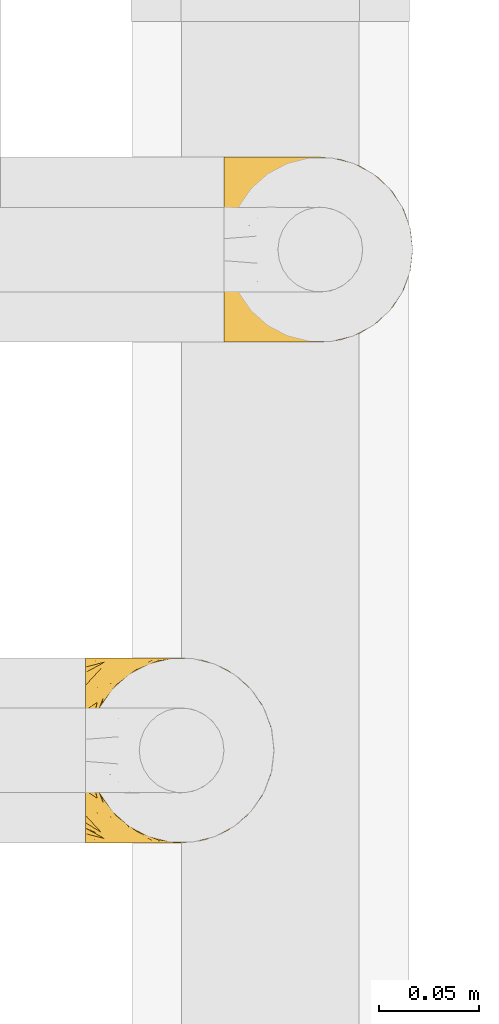
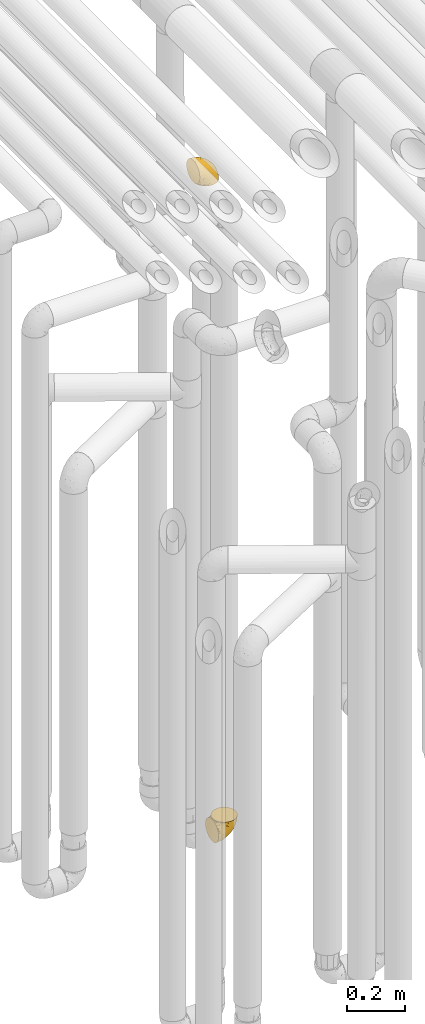
# One storey, part 224 of 827: 2 coverings.
"""IFC2X3 building model written with IfcOpenShell, lengths in millimetres."""

from ifc_helpers import new_model, entity, si_unit, converted_unit, derived_unit, direction, frame, origin, place, context, subcontext, project, spatial, faceted_brep, element, save


model = new_model("IFC2X3")

# Units and contexts
model_context = context("Model", 3, precision=0.01, world=origin(), true_north=direction((6.12303176911189e-17, 1.0)))
body_context = subcontext(model_context, "Body", "Model", "MODEL_VIEW")
ifc_project = project(units=[si_unit("LENGTHUNIT", "METRE", prefix="MILLI"), si_unit("AREAUNIT", "SQUARE_METRE"), si_unit("VOLUMEUNIT", "CUBIC_METRE"), converted_unit("PLANEANGLEUNIT", "DEGREE", entity("IfcRatioMeasure", 0.0174532925199433), si_unit("PLANEANGLEUNIT", "RADIAN"), dimensions=[0, 0, 0, 0, 0, 0, 0]), si_unit("MASSUNIT", "GRAM", prefix="KILO"), derived_unit("MASSDENSITYUNIT", [(si_unit("MASSUNIT", "GRAM", prefix="KILO"), 1), (si_unit("LENGTHUNIT", "METRE"), -3)]), derived_unit("MOMENTOFINERTIAUNIT", [(si_unit("LENGTHUNIT", "METRE"), 4)]), si_unit("TIMEUNIT", "SECOND"), si_unit("FREQUENCYUNIT", "HERTZ"), si_unit("THERMODYNAMICTEMPERATUREUNIT", "DEGREE_CELSIUS"), derived_unit("THERMALTRANSMITTANCEUNIT", [(si_unit("MASSUNIT", "GRAM", prefix="KILO"), 1), (si_unit("THERMODYNAMICTEMPERATUREUNIT", "KELVIN"), -1), (si_unit("TIMEUNIT", "SECOND"), -3)]), derived_unit("VOLUMETRICFLOWRATEUNIT", [(si_unit("LENGTHUNIT", "METRE"), 3), (si_unit("TIMEUNIT", "SECOND"), -1)]), derived_unit("MASSFLOWRATEUNIT", [(si_unit("MASSUNIT", "GRAM", prefix="KILO"), 1), (si_unit("TIMEUNIT", "SECOND"), -1)]), derived_unit("ROTATIONALFREQUENCYUNIT", [(si_unit("TIMEUNIT", "SECOND"), -1)]), si_unit("ELECTRICCURRENTUNIT", "AMPERE"), si_unit("ELECTRICVOLTAGEUNIT", "VOLT"), si_unit("POWERUNIT", "WATT"), si_unit("FORCEUNIT", "NEWTON", prefix="KILO"), si_unit("ILLUMINANCEUNIT", "LUX"), si_unit("LUMINOUSFLUXUNIT", "LUMEN"), si_unit("LUMINOUSINTENSITYUNIT", "CANDELA"), derived_unit("USERDEFINED", [(si_unit("MASSUNIT", "GRAM", prefix="KILO"), -1), (si_unit("LENGTHUNIT", "METRE"), -2), (si_unit("TIMEUNIT", "SECOND"), 3), (si_unit("LUMINOUSFLUXUNIT", "LUMEN"), 1)]), derived_unit("LINEARVELOCITYUNIT", [(si_unit("LENGTHUNIT", "METRE"), 1), (si_unit("TIMEUNIT", "SECOND"), -1)]), si_unit("PRESSUREUNIT", "PASCAL"), derived_unit("USERDEFINED", [(si_unit("LENGTHUNIT", "METRE"), -2), (si_unit("MASSUNIT", "GRAM", prefix="KILO"), 1), (si_unit("TIMEUNIT", "SECOND"), -2)]), derived_unit("LINEARFORCEUNIT", [(si_unit("MASSUNIT", "GRAM", prefix="KILO"), 1), (si_unit("LENGTHUNIT", "METRE"), 1), (si_unit("TIMEUNIT", "SECOND"), -2), (si_unit("LENGTHUNIT", "METRE"), -1)]), derived_unit("PLANARFORCEUNIT", [(si_unit("MASSUNIT", "GRAM", prefix="KILO"), 1), (si_unit("LENGTHUNIT", "METRE"), 1), (si_unit("TIMEUNIT", "SECOND"), -2), (si_unit("LENGTHUNIT", "METRE"), -2)])], contexts=[model_context])

# Site, building, storey
site_placement = place(None, origin())
site = spatial("IfcSite", under=ifc_project, at=site_placement, CompositionType="ELEMENT")
building_placement = place(site_placement, origin())
building = spatial("IfcBuilding", under=site, at=building_placement, CompositionType="ELEMENT")
storey_placement = place(building_placement, frame((0.0, 0.0, 28200.0)))
storey = spatial("IfcBuildingStorey", under=building, at=storey_placement, Name="08", CompositionType="ELEMENT", Elevation=28200.0)

# Coverings
covering_1_placement = place(storey_placement, frame((35824.19, 12708.37, 352.2)))
element("IfcCovering", 1, at=covering_1_placement, inside=storey, Name=":ADSK_", ObjectType=":ADSK_", PredefinedType="INSULATION", context=body_context, shape_type="Brep", body=[
    faceted_brep([(1.6, 83.91, 18.98), (1.6, 76.59, 11.67), (1.6, 67.83, 6.17), (1.6, 58.07, 2.75), (1.6, 47.8, 1.6), (1.6, 37.51, 2.75), (1.6, 27.74, 6.17), (1.6, 18.98, 11.68), (1.6, 11.67, 19.0), (1.6, 6.17, 27.76), (1.6, 2.75, 37.52), (1.6, 1.6, 47.8), (1.6, 2.06, 51.94), (1.6, 2.41, 55.01), (1.6, 2.75, 58.08), (1.6, 4.46, 62.96), (1.6, 6.17, 67.85), (1.6, 8.93, 72.23), (1.6, 11.68, 76.61), (1.6, 15.34, 80.26), (1.6, 19.0, 83.92), (1.6, 27.76, 89.42), (1.6, 32.64, 91.13), (1.6, 37.52, 92.84), (1.6, 47.8, 94.0), (1.6, 58.08, 92.84), (1.6, 62.96, 91.13), (1.6, 67.85, 89.42), (1.6, 76.61, 83.91), (1.6, 80.26, 80.25), (1.6, 83.92, 76.59), (1.6, 86.67, 72.21), (1.6, 89.42, 67.83), (1.6, 91.13, 62.95), (1.6, 92.84, 58.07), (1.6, 93.18, 55.0), (1.6, 93.53, 51.94), (1.6, 94.0, 47.8), (1.6, 92.84, 37.51), (1.6, 89.42, 27.74), (3.4, 47.8, 95.8), (4.97, 35.84, 95.8), (9.58, 24.7, 95.8), (13.26, 19.91, 95.8), (16.93, 15.13, 95.8), (21.71, 11.46, 95.8), (26.5, 7.78, 95.8), (32.07, 5.48, 95.8), (37.64, 3.17, 95.8), (41.25, 2.69, 95.8), (43.34, 2.42, 95.8), (45.42, 2.14, 95.8), (49.6, 1.6, 95.8), (61.55, 3.17, 95.8), (72.7, 7.78, 95.8), (82.26, 15.13, 95.8), (89.61, 24.7, 95.8), (94.22, 35.84, 95.8), (95.8, 47.8, 95.8), (94.22, 59.75, 95.8), (89.61, 70.9, 95.8), (82.26, 80.46, 95.8), (72.7, 87.81, 95.8), (61.55, 92.42, 95.8), (49.6, 94.0, 95.8), (45.42, 93.45, 95.8), (41.25, 92.9, 95.8), (37.64, 92.42, 95.8), (32.07, 90.11, 95.8), (26.5, 87.81, 95.8), (21.71, 84.13, 95.8), (16.93, 80.46, 95.8), (13.26, 75.68, 95.8), (9.58, 70.9, 95.8), (4.97, 59.75, 95.8), (81.55, 71.98, 60.58), (90.4, 63.6, 74.11), (83.0, 59.72, 51.59), (91.18, 47.8, 66.69), (93.13, 55.16, 76.19), (94.0, 47.8, 84.43), (66.19, 63.76, 31.2), (70.92, 72.22, 42.88), (85.95, 74.18, 79.41), (49.74, 92.52, 60.7), (35.54, 94.0, 61.85), (38.14, 94.0, 65.75), (40.74, 94.0, 69.64), (43.34, 94.0, 73.53), (45.94, 94.0, 77.43), (77.59, 82.14, 74.59), (71.17, 80.34, 54.72), (65.81, 87.52, 64.18), (59.03, 79.59, 37.94), (45.85, 78.25, 25.89), (45.79, 85.01, 34.73), (41.42, 90.25, 42.89), (34.51, 93.2, 49.83), (56.04, 87.23, 48.58), (15.15, 85.55, 22.41), (56.51, 93.0, 78.69), (68.39, 89.31, 81.64), (23.33, 61.31, 6.22), (42.86, 56.86, 12.11), (39.42, 68.34, 14.81), (53.58, 65.71, 21.61), (59.17, 56.99, 22.41), (59.06, 72.15, 30.12), (22.63, 70.34, 10.01), (20.55, 78.36, 15.36), (12.96, 47.8, 3.39), (56.96, 47.8, 19.59), (67.38, 47.8, 30.01), (18.72, 93.06, 41.19), (5.33, 94.0, 48.54), (9.07, 94.0, 49.28), (11.79, 94.0, 49.82), (14.51, 94.0, 50.37), (17.24, 94.0, 50.91), (19.96, 94.0, 51.45), (21.03, 89.88, 31.61), (46.48, 94.0, 80.15), (47.03, 94.0, 82.88), (47.57, 94.0, 85.6), (48.11, 94.0, 88.32), (48.48, 94.0, 90.19), (48.85, 94.0, 92.06), (30.7, 47.8, 6.21), (23.86, 94.0, 54.05), (27.75, 94.0, 56.65), (31.64, 94.0, 59.25), (31.26, 83.7, 24.66), (77.8, 47.8, 40.43), (72.75, 55.9, 35.17), (43.83, 47.8, 12.9), (84.49, 47.8, 53.56), (14.58, 81.75, 85.34), (16.17, 86.43, 78.44), (10.82, 79.8, 84.37), (4.64, 69.84, 89.05), (7.71, 79.5, 82.76), (25.13, 88.08, 86.31), (32.66, 91.6, 83.73), (34.94, 92.93, 77.31), (36.76, 92.43, 87.78), (40.48, 93.24, 87.91), (39.25, 93.36, 81.29), (3.69, 57.25, 93.97), (13.99, 89.41, 70.76), (21.85, 92.89, 63.67), (17.93, 92.66, 62.62), (15.11, 79.58, 90.64), (21.14, 86.51, 84.08), (7.21, 83.91, 77.45), (9.47, 88.76, 70.34), (32.27, 90.94, 88.72), (25.68, 91.94, 71.28), (22.18, 91.98, 68.09), (18.79, 82.79, 91.07), (10.12, 93.16, 57.47), (10.45, 73.94, 91.35), (11.29, 91.89, 62.99), (2.87, 47.8, 94.52), (31.16, 92.22, 76.47), (12.7, 86.29, 76.28), (6.31, 88.56, 69.96), (25.62, 87.72, 89.86), (21.18, 88.33, 78.94), (28.81, 92.18, 73.51), (7.45, 71.78, 89.62), (21.14, 9.09, 84.09), (25.13, 7.51, 86.3), (18.79, 12.8, 91.06), (48.11, 1.6, 88.32), (48.85, 1.6, 92.06), (47.03, 1.6, 82.88), (47.57, 1.6, 85.6), (3.69, 38.35, 93.97), (7.44, 23.84, 89.63), (14.51, 1.6, 50.37), (11.79, 1.6, 49.82), (5.33, 1.6, 48.54), (9.07, 1.6, 49.28), (7.71, 16.1, 82.77), (9.47, 6.84, 70.36), (34.94, 2.66, 77.31), (31.16, 3.37, 76.47), (40.74, 1.6, 69.64), (38.14, 1.6, 65.75), (36.76, 3.16, 87.78), (40.48, 2.35, 87.91), (4.63, 25.77, 89.06), (15.11, 16.02, 90.65), (14.58, 13.85, 85.35), (43.34, 1.6, 73.53), (45.94, 1.6, 77.43), (39.25, 2.23, 81.29), (7.21, 11.69, 77.46), (12.69, 9.31, 76.29), (10.14, 2.43, 57.47), (21.81, 2.71, 63.71), (22.19, 3.61, 68.11), (14.0, 6.18, 70.77), (25.69, 3.66, 71.31), (16.17, 9.17, 78.46), (6.66, 6.77, 69.52), (17.92, 2.93, 62.64), (10.45, 21.66, 91.35), (31.64, 1.6, 59.25), (10.64, 16.09, 84.6), (11.31, 3.7, 62.98), (19.96, 1.6, 51.45), (23.86, 1.6, 54.05), (27.75, 1.6, 56.65), (32.66, 3.99, 83.73), (46.48, 1.6, 80.15), (32.27, 4.65, 88.72), (35.54, 1.6, 61.85), (28.77, 3.43, 73.56), (21.17, 7.27, 78.96), (23.36, 9.46, 91.36), (17.24, 1.6, 50.91), (47.58, 2.4, 62.87), (93.13, 40.43, 76.19), (77.44, 13.57, 73.57), (66.78, 11.3, 56.07), (71.68, 18.65, 49.77), (74.96, 27.26, 44.73), (81.55, 23.61, 60.58), (36.7, 3.07, 47.64), (56.9, 2.69, 78.32), (83.0, 35.87, 51.59), (90.4, 31.99, 74.11), (67.83, 6.71, 76.04), (85.95, 21.41, 79.41), (39.41, 27.24, 14.82), (23.33, 34.26, 6.22), (42.87, 38.73, 12.12), (53.92, 26.97, 23.51), (66.19, 31.83, 31.2), (64.12, 23.4, 34.96), (33.13, 6.91, 33.86), (23.1, 3.4, 38.94), (16.98, 5.84, 30.23), (72.75, 39.69, 35.17), (23.77, 17.6, 15.85), (18.41, 10.38, 22.59), (43.7, 20.6, 21.56), (54.53, 5.36, 55.94), (55.72, 35.73, 20.67), (17.73, 24.84, 9.19), (38.98, 13.87, 25.79), (50.28, 9.06, 41.16), (59.02, 15.99, 37.95)], [[[0, 1, 2, 3, 4, 5, 6, 7, 8, 9, 10, 11, 12, 13, 14, 15, 16, 17, 18, 19, 20, 21, 22, 23, 24, 25, 26, 27, 28, 29, 30, 31, 32, 33, 34, 35, 36, 37, 38, 39]], [[40, 41, 42, 43, 44, 45, 46, 47, 48, 49, 50, 51, 52, 53, 54, 55, 56, 57, 58, 59, 60, 61, 62, 63, 64, 65, 66, 67, 68, 69, 70, 71, 72, 73, 74]], [[75, 76, 77]], [[78, 79, 80]], [[77, 81, 82]], [[76, 75, 83]], [[84, 85, 86, 87, 88, 89]], [[90, 91, 92]], [[76, 60, 59]], [[93, 94, 95]], [[90, 62, 61]], [[83, 61, 60]], [[96, 97, 84]], [[98, 93, 95]], [[0, 39, 99]], [[100, 84, 89]], [[62, 101, 63]], [[2, 102, 3]], [[92, 84, 100]], [[103, 102, 104]], [[103, 105, 106]], [[93, 107, 94]], [[1, 108, 2]], [[92, 101, 90]], [[108, 1, 109]], [[102, 110, 3]], [[93, 82, 107]], [[102, 108, 104]], [[111, 106, 112]], [[109, 0, 99]], [[113, 37, 114, 115, 116, 117, 118, 119]], [[120, 38, 113]], [[100, 89, 121, 122, 123, 124, 125, 126, 64]], [[127, 102, 103]], [[97, 119, 128, 129, 130, 85]], [[99, 120, 131]], [[132, 133, 77]], [[59, 80, 79]], [[1, 0, 109]], [[98, 84, 92]], [[94, 109, 131]], [[120, 39, 38]], [[93, 91, 82]], [[104, 94, 105]], [[97, 113, 119]], [[95, 120, 96]], [[83, 90, 61]], [[91, 93, 98]], [[64, 63, 100]], [[100, 63, 101]], [[77, 76, 79]], [[133, 106, 81]], [[84, 97, 85]], [[113, 96, 120]], [[113, 97, 96]], [[37, 113, 38]], [[110, 102, 127]], [[110, 4, 3]], [[103, 111, 134, 127]], [[90, 75, 91]], [[82, 81, 107]], [[91, 75, 82]], [[77, 82, 75]], [[76, 83, 60]], [[90, 83, 75]], [[105, 107, 81]], [[94, 131, 95]], [[105, 94, 107]], [[109, 94, 104]], [[120, 95, 131]], [[98, 95, 96]], [[84, 98, 96]], [[98, 92, 91]], [[106, 105, 81]], [[103, 104, 105]], [[133, 132, 112]], [[103, 106, 111]], [[77, 78, 135, 132]], [[106, 133, 112]], [[77, 133, 81]], [[120, 99, 39]], [[109, 99, 131]], [[59, 58, 80]], [[59, 79, 76]], [[90, 101, 62]], [[100, 101, 92]], [[2, 108, 102]], [[109, 104, 108]], [[78, 77, 79]], [[136, 137, 138]], [[27, 139, 140]], [[141, 142, 143]], [[144, 145, 121]], [[146, 89, 88]], [[147, 139, 25]], [[148, 149, 150]], [[136, 151, 152]], [[147, 40, 74]], [[24, 147, 25]], [[153, 148, 154]], [[33, 116, 34]], [[73, 72, 151]], [[114, 37, 36, 35, 34, 116, 115]], [[146, 155, 144]], [[156, 85, 130]], [[157, 149, 148]], [[151, 158, 152]], [[117, 33, 159]], [[29, 153, 154]], [[160, 74, 73]], [[161, 128, 119]], [[66, 65, 64, 126, 125, 124, 123, 122, 67]], [[162, 147, 24]], [[27, 140, 28]], [[149, 129, 150]], [[139, 27, 26, 25]], [[68, 144, 69]], [[129, 128, 150]], [[163, 87, 86]], [[130, 129, 149]], [[122, 145, 67]], [[153, 164, 148]], [[161, 119, 159]], [[165, 30, 154]], [[150, 154, 148]], [[128, 161, 150]], [[30, 165, 31]], [[145, 144, 68]], [[89, 146, 144]], [[87, 163, 143]], [[166, 155, 142]], [[88, 87, 143]], [[161, 154, 150]], [[154, 30, 29]], [[29, 28, 153]], [[28, 140, 153]], [[164, 153, 140]], [[140, 137, 164]], [[157, 148, 164]], [[156, 130, 157]], [[164, 137, 157]], [[157, 137, 156]], [[167, 137, 136]], [[168, 85, 156]], [[152, 168, 167]], [[167, 168, 156]], [[163, 152, 141]], [[71, 158, 72]], [[152, 167, 136]], [[88, 142, 146]], [[144, 155, 69]], [[146, 142, 155]], [[70, 166, 71]], [[142, 141, 166]], [[70, 69, 155]], [[141, 158, 71]], [[160, 73, 151]], [[138, 137, 140]], [[160, 136, 169]], [[136, 160, 151]], [[74, 160, 169]], [[152, 158, 141]], [[151, 72, 158]], [[168, 152, 163]], [[137, 167, 156]], [[163, 86, 168]], [[85, 168, 86]], [[116, 33, 117]], [[130, 149, 157]], [[67, 145, 68]], [[121, 89, 144]], [[145, 122, 121]], [[40, 147, 162]], [[169, 147, 74]], [[159, 33, 32]], [[161, 159, 32]], [[159, 119, 118, 117]], [[139, 147, 169]], [[139, 169, 138]], [[161, 32, 31]], [[141, 143, 163]], [[88, 143, 142]], [[71, 166, 141]], [[155, 166, 70]], [[139, 138, 140]], [[169, 136, 138]], [[154, 161, 165]], [[161, 31, 165]], [[170, 171, 172]], [[173, 174, 52, 51, 50, 49, 48, 175, 176]], [[177, 178, 41]], [[179, 15, 180]], [[12, 11, 181, 182, 180, 14, 13]], [[183, 21, 20]], [[19, 18, 184]], [[185, 186, 187]], [[186, 188, 187]], [[43, 172, 44]], [[189, 190, 47]], [[23, 22, 21, 191]], [[170, 192, 193]], [[40, 162, 177]], [[194, 195, 196]], [[24, 23, 177]], [[197, 198, 183]], [[199, 15, 179]], [[47, 46, 189]], [[200, 201, 202]], [[201, 203, 204]], [[205, 206, 184]], [[207, 41, 178]], [[16, 15, 199]], [[14, 180, 15]], [[202, 201, 198]], [[208, 201, 200]], [[162, 24, 177]], [[48, 47, 190]], [[196, 195, 189]], [[197, 184, 202]], [[204, 193, 209]], [[210, 211, 212]], [[206, 212, 213]], [[205, 17, 210]], [[184, 206, 202]], [[210, 212, 206]], [[185, 194, 214]], [[189, 215, 190]], [[216, 45, 214]], [[186, 171, 170]], [[189, 216, 196]], [[19, 184, 197]], [[194, 185, 187]], [[19, 197, 20]], [[198, 197, 202]], [[183, 20, 197]], [[206, 200, 202]], [[204, 183, 198]], [[201, 208, 203]], [[203, 208, 217]], [[204, 198, 201]], [[217, 188, 218]], [[193, 219, 170]], [[171, 186, 185]], [[170, 218, 186]], [[170, 219, 218]], [[42, 207, 192]], [[171, 220, 172]], [[216, 189, 46]], [[214, 194, 196]], [[44, 220, 45]], [[214, 196, 216]], [[216, 46, 45]], [[214, 45, 220]], [[192, 43, 42]], [[204, 203, 219]], [[207, 193, 192]], [[209, 193, 178]], [[41, 207, 42]], [[193, 207, 178]], [[43, 192, 172]], [[170, 172, 192]], [[204, 219, 193]], [[219, 203, 218]], [[217, 218, 203]], [[188, 186, 218]], [[206, 213, 200]], [[208, 200, 213]], [[199, 210, 16]], [[215, 189, 195]], [[215, 175, 190]], [[175, 48, 190]], [[199, 179, 221, 211]], [[210, 199, 211]], [[23, 191, 177]], [[40, 177, 41]], [[183, 209, 191]], [[183, 191, 21]], [[191, 178, 177]], [[205, 18, 17]], [[17, 16, 210]], [[171, 185, 214]], [[172, 220, 44]], [[214, 220, 171]], [[191, 209, 178]], [[204, 209, 183]], [[206, 205, 210]], [[18, 205, 184]], [[222, 195, 194, 187, 188, 217]], [[57, 223, 80]], [[224, 225, 226]], [[226, 227, 228]], [[229, 217, 208, 213, 212, 211]], [[230, 52, 174, 173, 176, 175, 215, 195]], [[231, 232, 228]], [[231, 78, 223]], [[223, 57, 232]], [[224, 233, 225]], [[233, 54, 53]], [[234, 232, 56]], [[56, 55, 234]], [[234, 224, 228]], [[235, 236, 237]], [[224, 55, 54]], [[238, 239, 240]], [[52, 230, 53]], [[241, 242, 243]], [[227, 244, 231]], [[11, 10, 242]], [[236, 6, 5]], [[7, 245, 8]], [[8, 246, 9]], [[238, 247, 235]], [[222, 229, 248]], [[242, 211, 221, 179, 180, 182, 181, 11]], [[233, 53, 230]], [[111, 112, 249]], [[250, 6, 236]], [[246, 251, 241]], [[6, 250, 7]], [[127, 236, 110]], [[248, 229, 252]], [[246, 8, 245]], [[235, 245, 250]], [[236, 5, 110]], [[235, 249, 238]], [[237, 236, 127]], [[243, 9, 246]], [[252, 229, 241]], [[56, 232, 57]], [[222, 230, 195]], [[225, 248, 252]], [[248, 233, 230]], [[54, 233, 224]], [[231, 228, 227]], [[244, 132, 231]], [[248, 225, 233]], [[226, 225, 253]], [[235, 250, 236]], [[245, 7, 250]], [[251, 246, 245]], [[243, 246, 241]], [[247, 245, 235]], [[252, 251, 253]], [[229, 222, 217]], [[230, 222, 248]], [[5, 4, 110]], [[237, 127, 134, 111]], [[238, 249, 239]], [[224, 234, 55]], [[232, 234, 228]], [[242, 241, 229]], [[10, 9, 243]], [[211, 242, 229]], [[10, 243, 242]], [[80, 223, 78]], [[80, 58, 57]], [[231, 223, 232]], [[227, 240, 239]], [[224, 226, 228]], [[240, 226, 253]], [[227, 239, 244]], [[226, 240, 227]], [[251, 247, 253]], [[240, 253, 247]], [[249, 235, 237]], [[237, 111, 249]], [[112, 132, 244]], [[112, 244, 249]], [[78, 231, 132, 135]], [[249, 244, 239]], [[247, 238, 240]], [[245, 247, 251]], [[251, 252, 241]], [[225, 252, 253]]]),
])
covering_2_placement = place(storey_placement, frame((35893.45, 12958.41, 2950.4)))
element("IfcCovering", 2, at=covering_2_placement, inside=storey, Name=":ADSK_", ObjectType=":ADSK_", PredefinedType="INSULATION", context=body_context, shape_type="Brep", body=[
    faceted_brep([(78.41, 83.91, 1.6), (85.72, 76.59, 1.6), (91.22, 67.83, 1.6), (94.64, 58.07, 1.6), (95.8, 47.8, 1.6), (94.64, 37.51, 1.6), (91.22, 27.74, 1.6), (85.71, 18.98, 1.6), (78.39, 11.67, 1.6), (69.63, 6.17, 1.6), (59.87, 2.75, 1.6), (49.6, 1.6, 1.6), (45.45, 2.06, 1.6), (42.38, 2.41, 1.6), (39.31, 2.75, 1.6), (34.43, 4.46, 1.6), (29.54, 6.17, 1.6), (25.16, 8.93, 1.6), (20.78, 11.68, 1.6), (17.13, 15.34, 1.6), (13.47, 19.0, 1.6), (7.97, 27.76, 1.6), (6.26, 32.64, 1.6), (4.55, 37.52, 1.6), (3.4, 47.8, 1.6), (4.55, 58.08, 1.6), (6.26, 62.96, 1.6), (7.97, 67.85, 1.6), (13.48, 76.61, 1.6), (17.14, 80.26, 1.6), (20.8, 83.92, 1.6), (25.18, 86.67, 1.6), (29.56, 89.42, 1.6), (34.44, 91.13, 1.6), (39.32, 92.84, 1.6), (42.39, 93.18, 1.6), (45.45, 93.53, 1.6), (49.6, 94.0, 1.6), (59.88, 92.84, 1.6), (69.65, 89.42, 1.6), (1.6, 47.8, 3.4), (1.6, 35.84, 4.97), (1.6, 24.7, 9.58), (1.6, 19.91, 13.26), (1.6, 15.13, 16.93), (1.6, 11.46, 21.71), (1.6, 7.78, 26.5), (1.6, 5.48, 32.07), (1.6, 3.17, 37.64), (1.6, 2.69, 41.25), (1.6, 2.42, 43.34), (1.6, 2.14, 45.42), (1.6, 1.6, 49.6), (1.6, 3.17, 61.55), (1.6, 7.78, 72.7), (1.6, 15.13, 82.26), (1.6, 24.7, 89.61), (1.6, 35.84, 94.22), (1.6, 47.8, 95.8), (1.6, 59.75, 94.22), (1.6, 70.9, 89.61), (1.6, 80.46, 82.26), (1.6, 87.81, 72.7), (1.6, 92.42, 61.55), (1.6, 94.0, 49.6), (1.6, 93.45, 45.42), (1.6, 92.9, 41.25), (1.6, 92.42, 37.64), (1.6, 90.11, 32.07), (1.6, 87.81, 26.5), (1.6, 84.13, 21.71), (1.6, 80.46, 16.93), (1.6, 75.68, 13.26), (1.6, 70.9, 9.58), (1.6, 59.75, 4.97), (36.81, 71.98, 81.55), (23.28, 63.6, 90.4), (45.8, 59.72, 83.0), (30.7, 47.8, 91.18), (21.2, 55.16, 93.13), (12.96, 47.8, 94.0), (66.19, 63.76, 66.19), (54.51, 72.22, 70.92), (17.98, 74.18, 85.95), (36.69, 92.52, 49.74), (35.54, 94.0, 35.54), (31.64, 94.0, 38.14), (27.75, 94.0, 40.74), (23.86, 94.0, 43.34), (19.96, 94.0, 45.94), (22.8, 82.14, 77.59), (42.67, 80.34, 71.17), (33.21, 87.52, 65.81), (59.45, 79.59, 59.03), (71.5, 78.25, 45.85), (62.66, 85.01, 45.79), (54.5, 90.25, 41.42), (47.57, 93.2, 34.51), (48.81, 87.23, 56.04), (74.98, 85.55, 15.15), (18.7, 93.0, 56.51), (15.75, 89.31, 68.39), (91.17, 61.31, 23.33), (85.28, 56.86, 42.86), (82.58, 68.34, 39.42), (75.78, 65.71, 53.58), (74.98, 56.99, 59.17), (67.27, 72.15, 59.06), (87.38, 70.34, 22.63), (82.04, 78.36, 20.55), (94.0, 47.8, 12.96), (77.8, 47.8, 56.96), (67.38, 47.8, 67.38), (56.2, 93.06, 18.72), (48.85, 94.0, 5.33), (48.11, 94.0, 9.07), (47.57, 94.0, 11.79), (47.03, 94.0, 14.51), (46.48, 94.0, 17.24), (45.94, 94.0, 19.96), (65.78, 89.88, 21.03), (17.24, 94.0, 46.48), (14.51, 94.0, 47.03), (11.79, 94.0, 47.57), (9.07, 94.0, 48.11), (7.2, 94.0, 48.48), (5.33, 94.0, 48.85), (91.18, 47.8, 30.7), (43.34, 94.0, 23.86), (40.74, 94.0, 27.75), (38.14, 94.0, 31.64), (72.73, 83.7, 31.26), (56.96, 47.8, 77.8), (62.23, 55.9, 72.75), (84.49, 47.8, 43.83), (43.83, 47.8, 84.49), (12.05, 81.75, 14.58), (18.95, 86.43, 16.17), (13.02, 79.8, 10.82), (8.34, 69.84, 4.64), (14.63, 79.5, 7.71), (11.09, 88.08, 25.13), (13.66, 91.6, 32.66), (20.08, 92.93, 34.94), (9.61, 92.43, 36.76), (9.48, 93.24, 40.48), (16.1, 93.36, 39.25), (3.42, 57.25, 3.69), (26.63, 89.41, 13.99), (33.72, 92.89, 21.85), (34.77, 92.66, 17.93), (6.75, 79.58, 15.11), (13.31, 86.51, 21.14), (21.11, 86.29, 12.7), (19.94, 83.91, 7.21), (8.67, 90.94, 32.27), (26.11, 91.94, 25.68), (29.3, 91.98, 22.18), (6.32, 82.79, 18.79), (39.92, 93.16, 10.12), (27.05, 88.76, 9.47), (6.04, 73.94, 10.45), (34.4, 91.89, 11.29), (2.87, 47.8, 2.87), (20.92, 92.22, 31.16), (27.43, 88.56, 6.31), (7.54, 87.72, 25.62), (18.45, 88.33, 21.18), (23.88, 92.18, 28.81), (7.77, 71.78, 7.45), (13.3, 9.09, 21.14), (11.09, 7.51, 25.13), (6.33, 12.8, 18.79), (9.07, 1.6, 48.11), (5.33, 1.6, 48.85), (14.51, 1.6, 47.03), (11.79, 1.6, 47.57), (3.42, 38.35, 3.69), (7.76, 23.84, 7.44), (47.03, 1.6, 14.51), (47.57, 1.6, 11.79), (48.85, 1.6, 5.33), (48.11, 1.6, 9.07), (14.62, 16.1, 7.71), (27.03, 6.84, 9.47), (20.08, 2.66, 34.94), (20.92, 3.37, 31.16), (27.75, 1.6, 40.74), (31.64, 1.6, 38.14), (9.61, 3.16, 36.76), (9.48, 2.35, 40.48), (8.33, 25.77, 4.63), (6.74, 16.02, 15.11), (12.04, 13.85, 14.58), (23.86, 1.6, 43.34), (19.96, 1.6, 45.94), (16.1, 2.23, 39.25), (19.93, 11.69, 7.21), (21.1, 9.31, 12.69), (39.92, 2.43, 10.14), (33.68, 2.71, 21.81), (29.28, 3.61, 22.19), (26.62, 6.18, 14.0), (26.08, 3.66, 25.69), (18.93, 9.17, 16.17), (27.87, 6.77, 6.66), (34.75, 2.93, 17.92), (6.04, 21.66, 10.45), (38.14, 1.6, 31.64), (12.79, 16.09, 10.64), (34.41, 3.7, 11.31), (45.94, 1.6, 19.96), (43.34, 1.6, 23.86), (40.74, 1.6, 27.75), (13.66, 3.99, 32.66), (17.24, 1.6, 46.48), (8.67, 4.65, 32.27), (35.54, 1.6, 35.54), (23.83, 3.43, 28.77), (18.43, 7.27, 21.17), (6.03, 9.46, 23.36), (46.48, 1.6, 17.24), (34.52, 2.4, 47.58), (21.2, 40.43, 93.13), (23.82, 13.57, 77.44), (41.32, 11.3, 66.78), (47.62, 18.65, 71.68), (52.66, 27.26, 74.96), (36.81, 23.61, 81.55), (49.75, 3.07, 36.7), (19.07, 2.69, 56.9), (45.8, 35.87, 83.0), (23.28, 31.99, 90.4), (21.35, 6.71, 67.83), (17.98, 21.41, 85.95), (82.57, 27.24, 39.41), (91.17, 34.26, 23.33), (85.27, 38.73, 42.87), (73.89, 26.97, 53.92), (66.19, 31.83, 66.19), (62.43, 23.4, 64.12), (63.53, 6.91, 33.13), (58.45, 3.4, 23.1), (67.16, 5.84, 16.98), (62.22, 39.69, 72.75), (81.54, 17.6, 23.77), (74.8, 10.38, 18.41), (75.83, 20.6, 43.7), (41.45, 5.36, 54.53), (76.72, 35.73, 55.72), (88.2, 24.84, 17.73), (71.6, 13.87, 38.98), (56.23, 9.06, 50.28), (59.44, 15.99, 59.02)], [[[0, 1, 2, 3, 4, 5, 6, 7, 8, 9, 10, 11, 12, 13, 14, 15, 16, 17, 18, 19, 20, 21, 22, 23, 24, 25, 26, 27, 28, 29, 30, 31, 32, 33, 34, 35, 36, 37, 38, 39]], [[40, 41, 42, 43, 44, 45, 46, 47, 48, 49, 50, 51, 52, 53, 54, 55, 56, 57, 58, 59, 60, 61, 62, 63, 64, 65, 66, 67, 68, 69, 70, 71, 72, 73, 74]], [[75, 76, 77]], [[78, 79, 80]], [[77, 81, 82]], [[76, 75, 83]], [[84, 85, 86, 87, 88, 89]], [[90, 91, 92]], [[76, 60, 59]], [[93, 94, 95]], [[90, 62, 61]], [[83, 61, 60]], [[96, 97, 84]], [[98, 93, 95]], [[0, 39, 99]], [[100, 84, 89]], [[62, 101, 63]], [[2, 102, 3]], [[92, 84, 100]], [[103, 102, 104]], [[103, 105, 106]], [[93, 107, 94]], [[1, 108, 2]], [[92, 101, 90]], [[108, 1, 109]], [[102, 110, 3]], [[93, 82, 107]], [[102, 108, 104]], [[111, 106, 112]], [[109, 0, 99]], [[113, 37, 114, 115, 116, 117, 118, 119]], [[120, 38, 113]], [[100, 89, 121, 122, 123, 124, 125, 126, 64]], [[127, 102, 103]], [[97, 119, 128, 129, 130, 85]], [[99, 120, 131]], [[132, 133, 77]], [[59, 80, 79]], [[1, 0, 109]], [[98, 84, 92]], [[94, 109, 131]], [[120, 39, 38]], [[93, 91, 82]], [[104, 94, 105]], [[97, 113, 119]], [[95, 120, 96]], [[83, 90, 61]], [[91, 93, 98]], [[64, 63, 100]], [[100, 63, 101]], [[77, 76, 79]], [[133, 106, 81]], [[84, 97, 85]], [[113, 96, 120]], [[113, 97, 96]], [[37, 113, 38]], [[110, 102, 127]], [[110, 4, 3]], [[103, 111, 134, 127]], [[90, 75, 91]], [[82, 81, 107]], [[91, 75, 82]], [[77, 82, 75]], [[76, 83, 60]], [[90, 83, 75]], [[105, 107, 81]], [[94, 131, 95]], [[105, 94, 107]], [[109, 94, 104]], [[120, 95, 131]], [[98, 95, 96]], [[84, 98, 96]], [[98, 92, 91]], [[106, 105, 81]], [[103, 104, 105]], [[112, 106, 133]], [[103, 106, 111]], [[112, 133, 132]], [[81, 77, 133]], [[77, 78, 135, 132]], [[120, 99, 39]], [[109, 99, 131]], [[59, 58, 80]], [[59, 79, 76]], [[90, 101, 62]], [[100, 101, 92]], [[2, 108, 102]], [[109, 104, 108]], [[78, 77, 79]], [[136, 137, 138]], [[27, 139, 140]], [[141, 142, 143]], [[144, 145, 121]], [[146, 89, 88]], [[147, 139, 25]], [[148, 149, 150]], [[136, 151, 152]], [[147, 40, 74]], [[24, 147, 25]], [[140, 153, 154]], [[33, 116, 34]], [[73, 72, 151]], [[114, 37, 36, 35, 34, 116, 115]], [[146, 155, 144]], [[156, 85, 130]], [[157, 149, 148]], [[151, 158, 152]], [[117, 33, 159]], [[29, 154, 160]], [[161, 74, 73]], [[162, 128, 119]], [[66, 65, 64, 126, 125, 124, 123, 122, 67]], [[163, 147, 24]], [[27, 140, 28]], [[149, 129, 150]], [[139, 27, 26, 25]], [[68, 144, 69]], [[129, 128, 150]], [[164, 87, 86]], [[130, 129, 149]], [[122, 145, 67]], [[154, 153, 148]], [[162, 119, 159]], [[165, 30, 160]], [[150, 160, 148]], [[128, 162, 150]], [[30, 165, 31]], [[145, 144, 68]], [[89, 146, 144]], [[87, 164, 143]], [[166, 155, 142]], [[88, 87, 143]], [[162, 160, 150]], [[160, 30, 29]], [[154, 29, 28]], [[140, 154, 28]], [[160, 154, 148]], [[140, 137, 153]], [[157, 148, 153]], [[156, 130, 157]], [[153, 137, 157]], [[157, 137, 156]], [[167, 137, 136]], [[168, 85, 156]], [[152, 168, 167]], [[167, 168, 156]], [[164, 152, 141]], [[71, 158, 72]], [[152, 167, 136]], [[88, 142, 146]], [[144, 155, 69]], [[146, 142, 155]], [[70, 166, 71]], [[142, 141, 166]], [[70, 69, 155]], [[141, 158, 71]], [[161, 73, 151]], [[138, 137, 140]], [[161, 136, 169]], [[136, 161, 151]], [[74, 161, 169]], [[152, 158, 141]], [[151, 72, 158]], [[168, 152, 164]], [[137, 167, 156]], [[164, 86, 168]], [[85, 168, 86]], [[116, 33, 117]], [[130, 149, 157]], [[67, 145, 68]], [[121, 89, 144]], [[145, 122, 121]], [[40, 147, 163]], [[169, 147, 74]], [[159, 33, 32]], [[162, 159, 32]], [[159, 119, 118, 117]], [[139, 147, 169]], [[139, 169, 138]], [[162, 32, 31]], [[141, 143, 164]], [[88, 143, 142]], [[71, 166, 141]], [[155, 166, 70]], [[139, 138, 140]], [[169, 136, 138]], [[160, 162, 165]], [[162, 31, 165]], [[170, 171, 172]], [[173, 174, 52, 51, 50, 49, 48, 175, 176]], [[177, 178, 41]], [[179, 15, 180]], [[12, 11, 181, 182, 180, 14, 13]], [[183, 21, 20]], [[19, 18, 184]], [[185, 186, 187]], [[186, 188, 187]], [[43, 172, 44]], [[189, 190, 47]], [[23, 22, 21, 191]], [[170, 192, 193]], [[40, 163, 177]], [[194, 195, 196]], [[24, 23, 177]], [[197, 198, 183]], [[199, 15, 179]], [[47, 46, 189]], [[200, 201, 202]], [[201, 203, 204]], [[205, 206, 184]], [[207, 41, 178]], [[16, 15, 199]], [[14, 180, 15]], [[202, 201, 198]], [[208, 201, 200]], [[163, 24, 177]], [[48, 47, 190]], [[196, 195, 189]], [[197, 184, 202]], [[204, 193, 209]], [[210, 211, 212]], [[206, 212, 213]], [[205, 17, 210]], [[184, 206, 202]], [[210, 212, 206]], [[185, 194, 214]], [[189, 215, 190]], [[216, 45, 214]], [[186, 171, 170]], [[189, 216, 196]], [[197, 20, 19]], [[194, 185, 187]], [[197, 183, 20]], [[184, 197, 19]], [[197, 202, 198]], [[206, 200, 202]], [[204, 183, 198]], [[201, 208, 203]], [[203, 208, 217]], [[204, 198, 201]], [[217, 188, 218]], [[193, 219, 170]], [[171, 186, 185]], [[170, 218, 186]], [[170, 219, 218]], [[42, 207, 192]], [[171, 220, 172]], [[216, 189, 46]], [[214, 194, 196]], [[44, 220, 45]], [[214, 196, 216]], [[216, 46, 45]], [[214, 45, 220]], [[192, 43, 42]], [[204, 203, 219]], [[207, 193, 192]], [[209, 193, 178]], [[41, 207, 42]], [[193, 207, 178]], [[43, 192, 172]], [[170, 172, 192]], [[204, 219, 193]], [[219, 203, 218]], [[217, 218, 203]], [[188, 186, 218]], [[206, 213, 200]], [[208, 200, 213]], [[199, 210, 16]], [[215, 189, 195]], [[215, 175, 190]], [[175, 48, 190]], [[199, 179, 221, 211]], [[210, 199, 211]], [[23, 191, 177]], [[40, 177, 41]], [[178, 177, 191]], [[21, 183, 191]], [[209, 191, 183]], [[205, 18, 17]], [[17, 16, 210]], [[171, 185, 214]], [[172, 220, 44]], [[214, 220, 171]], [[191, 209, 178]], [[204, 209, 183]], [[206, 205, 210]], [[18, 205, 184]], [[222, 195, 194, 187, 188, 217]], [[57, 223, 80]], [[224, 225, 226]], [[226, 227, 228]], [[229, 217, 208, 213, 212, 211]], [[230, 52, 174, 173, 176, 175, 215, 195]], [[231, 232, 228]], [[231, 78, 223]], [[223, 57, 232]], [[224, 233, 225]], [[233, 54, 53]], [[234, 232, 56]], [[56, 55, 234]], [[234, 224, 228]], [[235, 236, 237]], [[224, 55, 54]], [[238, 239, 240]], [[52, 230, 53]], [[241, 242, 243]], [[227, 244, 231]], [[11, 10, 242]], [[236, 6, 5]], [[7, 245, 8]], [[8, 246, 9]], [[238, 247, 235]], [[222, 229, 248]], [[242, 211, 221, 179, 180, 182, 181, 11]], [[233, 53, 230]], [[111, 112, 249]], [[250, 6, 236]], [[246, 251, 241]], [[6, 250, 7]], [[127, 236, 110]], [[248, 229, 252]], [[246, 8, 245]], [[235, 245, 250]], [[236, 5, 110]], [[235, 249, 238]], [[237, 236, 127]], [[243, 9, 246]], [[252, 229, 241]], [[56, 232, 57]], [[222, 230, 195]], [[225, 248, 252]], [[248, 233, 230]], [[54, 233, 224]], [[231, 228, 227]], [[244, 132, 231]], [[248, 225, 233]], [[226, 225, 253]], [[235, 250, 236]], [[245, 7, 250]], [[251, 246, 245]], [[243, 246, 241]], [[247, 245, 235]], [[252, 251, 253]], [[229, 222, 217]], [[230, 222, 248]], [[5, 4, 110]], [[237, 127, 134, 111]], [[238, 249, 239]], [[224, 234, 55]], [[232, 234, 228]], [[242, 241, 229]], [[10, 9, 243]], [[211, 242, 229]], [[10, 243, 242]], [[80, 223, 78]], [[80, 58, 57]], [[231, 223, 232]], [[227, 240, 239]], [[224, 226, 228]], [[240, 226, 253]], [[227, 239, 244]], [[226, 240, 227]], [[251, 247, 253]], [[240, 253, 247]], [[249, 235, 237]], [[237, 111, 249]], [[112, 132, 244]], [[112, 244, 249]], [[78, 231, 132, 135]], [[249, 244, 239]], [[247, 238, 240]], [[245, 247, 251]], [[251, 252, 241]], [[225, 252, 253]]]),
])

save(model, "model.ifc")
